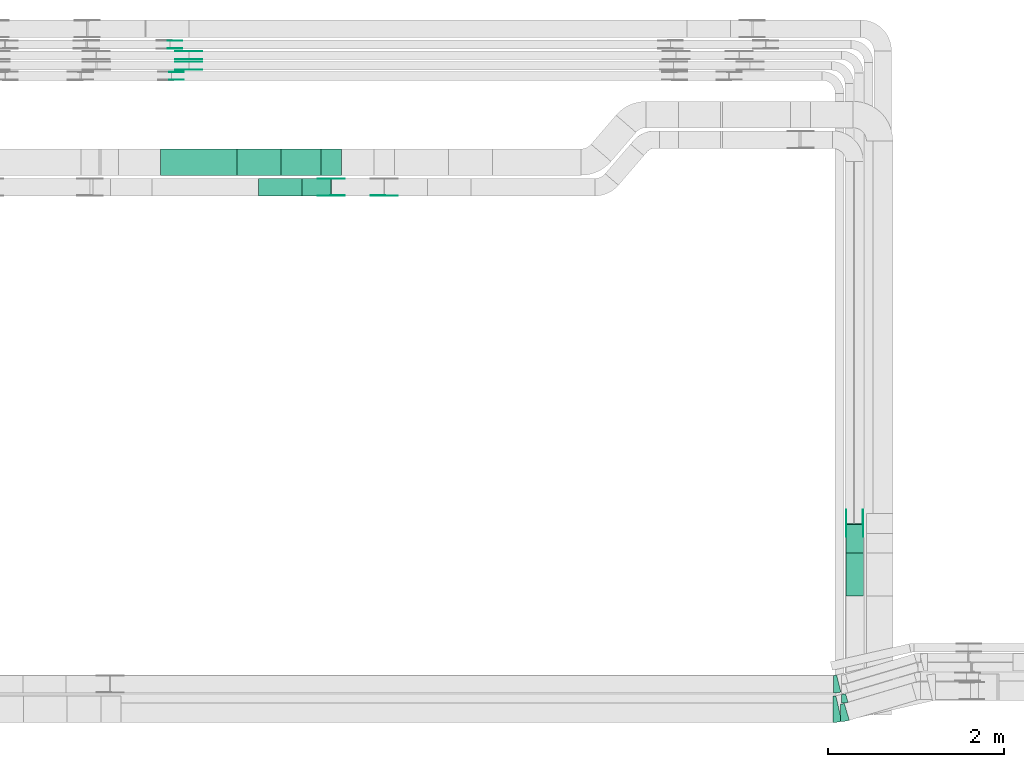
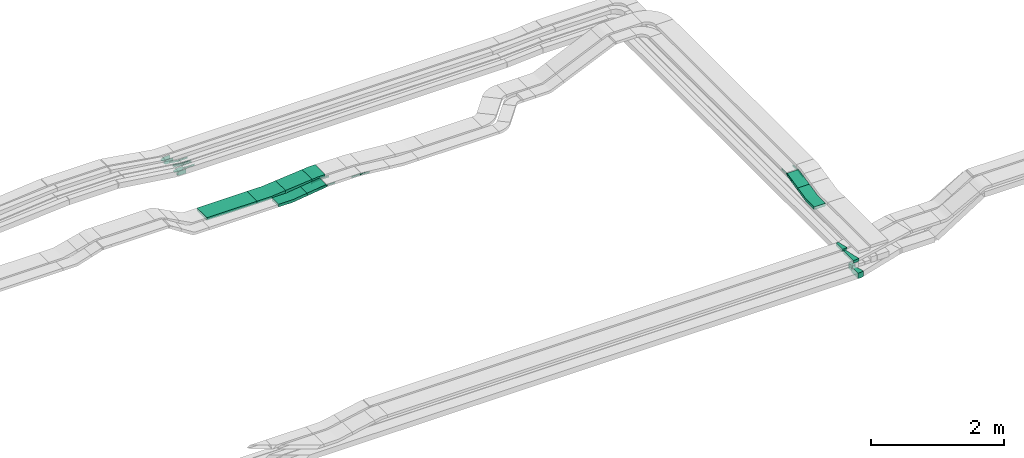
# One storey, part 19 of 28: 30 flow fittings, 4 flow segments.
"""IFC2X3 building model written with IfcOpenShell, lengths in millimetres."""

from ifc_helpers import new_model, entity, si_unit, converted_unit, derived_unit, direction, frame, frame_2d, origin, origin_2d_with_axis, place, context, subcontext, project, spatial, polyline, circle_curve, parameter, trimmed, segment, composite_curve, rectangle, outline, extrude, source, transform, mapped, material, type_object, type_shapes, element, save


model = new_model("IFC2X3")

# Units and contexts
model_context = context("Model", 3, precision=0.01, world=origin(), true_north=direction((6.12303176911189e-17, 1.0)))
body_context = subcontext(model_context, "Body", "Model", "MODEL_VIEW")
ifc_project = project(units=[si_unit("LENGTHUNIT", "METRE", prefix="MILLI"), si_unit("AREAUNIT", "SQUARE_METRE"), si_unit("VOLUMEUNIT", "CUBIC_METRE"), converted_unit("PLANEANGLEUNIT", "DEGREE", entity("IfcRatioMeasure", 0.0174532925199433), si_unit("PLANEANGLEUNIT", "RADIAN"), dimensions=[0, 0, 0, 0, 0, 0, 0]), si_unit("MASSUNIT", "GRAM", prefix="KILO"), derived_unit("MASSDENSITYUNIT", [(si_unit("MASSUNIT", "GRAM", prefix="KILO"), 1), (si_unit("LENGTHUNIT", "METRE"), -3)]), derived_unit("MOMENTOFINERTIAUNIT", [(si_unit("LENGTHUNIT", "METRE"), 4)]), si_unit("TIMEUNIT", "SECOND"), si_unit("FREQUENCYUNIT", "HERTZ"), si_unit("THERMODYNAMICTEMPERATUREUNIT", "DEGREE_CELSIUS"), derived_unit("THERMALTRANSMITTANCEUNIT", [(si_unit("MASSUNIT", "GRAM", prefix="KILO"), 1), (si_unit("THERMODYNAMICTEMPERATUREUNIT", "KELVIN"), -1), (si_unit("TIMEUNIT", "SECOND"), -3)]), derived_unit("VOLUMETRICFLOWRATEUNIT", [(si_unit("LENGTHUNIT", "METRE"), 3), (si_unit("TIMEUNIT", "SECOND"), -1)]), derived_unit("MASSFLOWRATEUNIT", [(si_unit("MASSUNIT", "GRAM", prefix="KILO"), 1), (si_unit("TIMEUNIT", "SECOND"), -1)]), derived_unit("ROTATIONALFREQUENCYUNIT", [(si_unit("TIMEUNIT", "SECOND"), -1)]), si_unit("ELECTRICCURRENTUNIT", "AMPERE"), si_unit("ELECTRICVOLTAGEUNIT", "VOLT"), si_unit("POWERUNIT", "WATT"), si_unit("FORCEUNIT", "NEWTON", prefix="KILO"), si_unit("ILLUMINANCEUNIT", "LUX"), si_unit("LUMINOUSFLUXUNIT", "LUMEN"), si_unit("LUMINOUSINTENSITYUNIT", "CANDELA"), derived_unit("USERDEFINED", [(si_unit("MASSUNIT", "GRAM", prefix="KILO"), -1), (si_unit("LENGTHUNIT", "METRE"), -2), (si_unit("TIMEUNIT", "SECOND"), 3), (si_unit("LUMINOUSFLUXUNIT", "LUMEN"), 1)]), derived_unit("LINEARVELOCITYUNIT", [(si_unit("LENGTHUNIT", "METRE"), 1), (si_unit("TIMEUNIT", "SECOND"), -1)]), si_unit("PRESSUREUNIT", "PASCAL"), derived_unit("USERDEFINED", [(si_unit("LENGTHUNIT", "METRE"), -2), (si_unit("MASSUNIT", "GRAM", prefix="KILO"), 1), (si_unit("TIMEUNIT", "SECOND"), -2)]), derived_unit("LINEARFORCEUNIT", [(si_unit("MASSUNIT", "GRAM", prefix="KILO"), 1), (si_unit("LENGTHUNIT", "METRE"), 1), (si_unit("TIMEUNIT", "SECOND"), -2), (si_unit("LENGTHUNIT", "METRE"), -1)]), derived_unit("PLANARFORCEUNIT", [(si_unit("MASSUNIT", "GRAM", prefix="KILO"), 1), (si_unit("LENGTHUNIT", "METRE"), 1), (si_unit("TIMEUNIT", "SECOND"), -2), (si_unit("LENGTHUNIT", "METRE"), -2)])], contexts=[model_context])

# Site, building, storey
site_placement = place(None, origin())
site = spatial("IfcSite", under=ifc_project, at=site_placement, CompositionType="ELEMENT")
building_placement = place(site_placement, origin())
building = spatial("IfcBuilding", under=site, at=building_placement, CompositionType="ELEMENT")
storey_placement = place(building_placement, frame((0.0, 0.0, 15900.0)))
storey = spatial("IfcBuildingStorey", under=building, at=storey_placement, CompositionType="ELEMENT", Elevation=15900.0)

# Flow segments
cable_carrier_segment_type = type_object("IfcCableCarrierSegmentType", PredefinedType="CABLETRAYSEGMENT")
flow_segment_1_placement = place(storey_placement, frame((52457.57, 14435.03, 2510.0)))
element("IfcFlowSegment", 1, at=flow_segment_1_placement, inside=storey, type_object=cable_carrier_segment_type, context=body_context, shape_type="SweptSolid", body=[
    extrude(rectangle(XDim=871.430907386971, YDim=300.000000000001, at=origin_2d_with_axis()), frame((435.72, 150.0, 0.0)), (0.0, 0.0, 1.0), 50.0000000000038),
])
flow_segment_2_placement = place(storey_placement, frame((54062.44, 14200.03, 2542.67)))
element("IfcFlowSegment", 2, at=flow_segment_2_placement, inside=storey, type_object=cable_carrier_segment_type, context=body_context, shape_type="SweptSolid", body=[
    extrude(rectangle(XDim=49.9999999999994, YDim=199.999999999998, at=origin_2d_with_axis()), frame((3.25, 100.0, 24.79), z_axis=(0.99149516870263, 0.0, 0.130143499412548), x_axis=(-0.130143499412548, 0.0, 0.99149516870263)), (0.0, 0.0, 1.0), 333.926965891303),
])
flow_segment_3_placement = place(storey_placement, frame((53824.38, 14435.03, 2533.18)))
element("IfcFlowSegment", 3, at=flow_segment_3_placement, inside=storey, type_object=cable_carrier_segment_type, context=body_context, shape_type="SweptSolid", body=[
    extrude(rectangle(XDim=50.0000000000003, YDim=300.000000000001, at=frame_2d((0.0, 0.0), x_axis=(0.0, 1.0))), frame((2.31, 150.0, 24.89), z_axis=(0.995712367928819, 0.0, 0.0925034072539187), x_axis=(0.0, 1.0, 0.0)), (0.0, 0.0, 1.0), 461.339846266049),
])
flow_segment_4_placement = place(storey_placement, frame((60246.82, 10142.24, 2935.93)))
element("IfcFlowSegment", 4, at=flow_segment_4_placement, inside=storey, type_object=cable_carrier_segment_type, context=body_context, shape_type="SweptSolid", body=[
    extrude(rectangle(XDim=49.999999999999, YDim=333.777983077564, at=frame_2d((0.0, 0.0), x_axis=(0.0, 1.0))), frame((0.0, 168.29, 61.26), z_axis=(1.0, 0.0, 0.0), x_axis=(0.0, -0.975283876332617, -0.220955562422909)), (0.0, 0.0, 1.0), 200.000000000007),
])

# Flow fittings
ifc_material_1 = material(Name="G")
cable_carrier_fitting_type_1 = type_object("IfcCableCarrierFittingType", PredefinedType="NOTDEFINED", material=ifc_material_1)
shared_shape_1 = source(origin(), body_context, "Body", "SweptSolid", [
    extrude(outline(composite_curve([segment(trimmed(circle_curve(frame_2d((-44.59, 0.0), x_axis=(1.0, 0.0)), 12.5), [parameter(90.0000000000007)], [parameter(270.0)], True, "PARAMETER"), True, "CONTINUOUS"), segment(polyline([(-44.59, -12.5), (-33.09, -12.5)]), True, "CONTINUOUS"), segment(polyline([(-33.09, -12.5), (-31.23, -14.5)]), True, "CONTINUOUS"), segment(polyline([(-31.23, -14.5), (108.91, -14.5)]), True, "CONTINUOUS"), segment(polyline([(108.91, -14.5), (108.91, 14.5)]), True, "CONTINUOUS"), segment(polyline([(108.91, 14.5), (-31.23, 14.5)]), True, "CONTINUOUS"), segment(polyline([(-31.23, 14.5), (-33.09, 12.5)]), True, "CONTINUOUS"), segment(polyline([(-33.09, 12.5), (-44.59, 12.5)]), True, "CONTINUOUS")], self_intersect=False)), frame((44.59, 0.0, 0.0), z_axis=(0.0, 0.0, -1.0), x_axis=(1.0, 0.0, 0.0)), (0.0, 0.0, -1.0), 2.0),
])
type_shapes(cable_carrier_fitting_type_1, [shared_shape_1])
flow_fitting_1_placement = place(storey_placement, frame((52777.82, 15634.0, 2642.36), z_axis=(0.0, -1.0, 0.0), x_axis=(1.0, 0.0, 0.0)))
element("IfcFlowFitting", 5, at=flow_fitting_1_placement, inside=storey, type_object=cable_carrier_fitting_type_1, material=ifc_material_1, context=body_context, shape_type="MappedRepresentation", body=[
    mapped(shared_shape_1, transform((0.0, 0.0, 0.0), scale=1.0)),
])
cable_carrier_fitting_type_2 = type_object("IfcCableCarrierFittingType", PredefinedType="NOTDEFINED", material=ifc_material_1)
type_shapes(cable_carrier_fitting_type_2, [shared_shape_1])
flow_fitting_2_placement = place(storey_placement, frame((52777.82, 15722.92, 2642.36), z_axis=(0.0, 1.0, 0.0), x_axis=(-0.990595007167102, 0.0, 0.136826648631067)))
element("IfcFlowFitting", 6, at=flow_fitting_2_placement, inside=storey, type_object=cable_carrier_fitting_type_2, material=ifc_material_1, context=body_context, shape_type="MappedRepresentation", body=[
    mapped(shared_shape_1, transform((0.0, 0.0, 0.0), scale=1.0)),
])
flow_fitting_3_placement = place(storey_placement, frame((52777.82, 15754.0, 2642.36), z_axis=(0.0, -1.0, 0.0), x_axis=(1.0, 0.0, 0.0)))
element("IfcFlowFitting", 7, at=flow_fitting_3_placement, inside=storey, type_object=cable_carrier_fitting_type_1, material=ifc_material_1, context=body_context, shape_type="MappedRepresentation", body=[
    mapped(shared_shape_1, transform((0.0, 0.0, 0.0), scale=1.0)),
])
flow_fitting_4_placement = place(storey_placement, frame((52777.82, 15842.92, 2642.36), z_axis=(0.0, 1.0, 0.0), x_axis=(-0.990663695538518, 0.0, 0.136328435559007)))
element("IfcFlowFitting", 8, at=flow_fitting_4_placement, inside=storey, type_object=cable_carrier_fitting_type_2, material=ifc_material_1, context=body_context, shape_type="MappedRepresentation", body=[
    mapped(shared_shape_1, transform((0.0, 0.0, 0.0), scale=1.0)),
])
flow_fitting_5_placement = place(storey_placement, frame((60442.28, 10477.43, 3035.0), z_axis=(1.0, 0.0, 0.0), x_axis=(0.0, -0.975283876332616, -0.220955562422916)))
element("IfcFlowFitting", 9, at=flow_fitting_5_placement, inside=storey, type_object=cable_carrier_fitting_type_1, material=ifc_material_1, context=body_context, shape_type="MappedRepresentation", body=[
    mapped(shared_shape_1, transform((0.0, 0.0, 0.0), scale=1.0)),
])
flow_fitting_6_placement = place(storey_placement, frame((60253.36, 10477.43, 3035.0), z_axis=(-1.0, 0.0, 0.0), x_axis=(0.0, 1.0, 0.0)))
element("IfcFlowFitting", 10, at=flow_fitting_6_placement, inside=storey, type_object=cable_carrier_fitting_type_2, material=ifc_material_1, context=body_context, shape_type="MappedRepresentation", body=[
    mapped(shared_shape_1, transform((0.0, 0.0, 0.0), scale=1.0)),
])
flow_fitting_7_placement = place(storey_placement, frame((54399.65, 14204.57, 2611.3), z_axis=(0.0, -1.0, 0.0), x_axis=(-0.991495168702633, 0.0, -0.130143499412525)))
element("IfcFlowFitting", 11, at=flow_fitting_7_placement, inside=storey, type_object=cable_carrier_fitting_type_1, material=ifc_material_1, context=body_context, shape_type="MappedRepresentation", body=[
    mapped(shared_shape_1, transform((0.0, 0.0, 0.0), scale=1.0)),
])
for number, where, z_axis, x_axis in (
    (12, (54399.65, 14393.49, 2611.3), (0.0, 1.0, 0.0), (1.0, 0.0, 0.0)),
    (13, (54998.38, 14206.57, 2611.3), (0.0, -1.0, 0.0), (-1.0, 0.0, 0.0)),
):
    element("IfcFlowFitting", number, at=place(storey_placement, frame(where, z_axis=z_axis, x_axis=x_axis)), inside=storey, type_object=cable_carrier_fitting_type_2, material=ifc_material_1, context=body_context, shape_type="MappedRepresentation", body=[
        mapped(shared_shape_1, transform((0.0, 0.0, 0.0), scale=1.0)),
    ])
cable_carrier_fitting_type_3 = type_object("IfcCableCarrierFittingType", PredefinedType="NOTDEFINED", material=ifc_material_1)
shared_shape_2 = source(origin(), body_context, "Body", "SweptSolid", [
    extrude(outline(composite_curve([segment(trimmed(circle_curve(frame_2d((-44.59, 0.0), x_axis=(1.0, 0.0)), 12.5), [parameter(90.0000000000007)], [parameter(270.0)], True, "PARAMETER"), True, "CONTINUOUS"), segment(polyline([(-44.59, -12.5), (-33.09, -12.5)]), True, "CONTINUOUS"), segment(polyline([(-33.09, -12.5), (-31.23, -14.5)]), True, "CONTINUOUS"), segment(polyline([(-31.23, -14.5), (108.91, -14.5)]), True, "CONTINUOUS"), segment(polyline([(108.91, -14.5), (108.91, 14.5)]), True, "CONTINUOUS"), segment(polyline([(108.91, 14.5), (-31.23, 14.5)]), True, "CONTINUOUS"), segment(polyline([(-31.23, 14.5), (-33.09, 12.5)]), True, "CONTINUOUS"), segment(polyline([(-33.09, 12.5), (-44.59, 12.5)]), True, "CONTINUOUS")], self_intersect=False)), frame((44.59, 0.0, 0.0)), (0.0, 0.0, 1.0), 2.0),
])
type_shapes(cable_carrier_fitting_type_3, [shared_shape_2])
flow_fitting_8_placement = place(storey_placement, frame((52777.82, 15724.92, 2642.36), z_axis=(0.0, 1.0, 0.0), x_axis=(1.0, 0.0, 0.0)))
element("IfcFlowFitting", 14, at=flow_fitting_8_placement, inside=storey, type_object=cable_carrier_fitting_type_3, material=ifc_material_1, context=body_context, shape_type="MappedRepresentation", body=[
    mapped(shared_shape_2, transform((0.0, 0.0, 0.0), scale=1.0)),
])
cable_carrier_fitting_type_4 = type_object("IfcCableCarrierFittingType", PredefinedType="NOTDEFINED", material=ifc_material_1)
type_shapes(cable_carrier_fitting_type_4, [shared_shape_2])
flow_fitting_9_placement = place(storey_placement, frame((52777.82, 15636.0, 2642.36), z_axis=(0.0, -1.0, 0.0), x_axis=(-0.990595007167102, 0.0, 0.136826648631067)))
element("IfcFlowFitting", 15, at=flow_fitting_9_placement, inside=storey, type_object=cable_carrier_fitting_type_4, material=ifc_material_1, context=body_context, shape_type="MappedRepresentation", body=[
    mapped(shared_shape_2, transform((0.0, 0.0, 0.0), scale=1.0)),
])
flow_fitting_10_placement = place(storey_placement, frame((52777.82, 15844.92, 2642.36), z_axis=(0.0, 1.0, 0.0), x_axis=(1.0, 0.0, 0.0)))
element("IfcFlowFitting", 16, at=flow_fitting_10_placement, inside=storey, type_object=cable_carrier_fitting_type_3, material=ifc_material_1, context=body_context, shape_type="MappedRepresentation", body=[
    mapped(shared_shape_2, transform((0.0, 0.0, 0.0), scale=1.0)),
])
flow_fitting_11_placement = place(storey_placement, frame((52777.82, 15756.0, 2642.36), z_axis=(0.0, -1.0, 0.0), x_axis=(-0.990663695538518, 0.0, 0.136328435559007)))
element("IfcFlowFitting", 17, at=flow_fitting_11_placement, inside=storey, type_object=cable_carrier_fitting_type_4, material=ifc_material_1, context=body_context, shape_type="MappedRepresentation", body=[
    mapped(shared_shape_2, transform((0.0, 0.0, 0.0), scale=1.0)),
])
flow_fitting_12_placement = place(storey_placement, frame((60251.36, 10477.43, 3035.0), z_axis=(-1.0, 0.0, 0.0), x_axis=(0.0, -0.975283876332616, -0.220955562422916)))
element("IfcFlowFitting", 18, at=flow_fitting_12_placement, inside=storey, type_object=cable_carrier_fitting_type_3, material=ifc_material_1, context=body_context, shape_type="MappedRepresentation", body=[
    mapped(shared_shape_2, transform((0.0, 0.0, 0.0), scale=1.0)),
])
flow_fitting_13_placement = place(storey_placement, frame((60440.28, 10477.43, 3035.0), z_axis=(1.0, 0.0, 0.0), x_axis=(0.0, 1.0, 0.0)))
element("IfcFlowFitting", 19, at=flow_fitting_13_placement, inside=storey, type_object=cable_carrier_fitting_type_4, material=ifc_material_1, context=body_context, shape_type="MappedRepresentation", body=[
    mapped(shared_shape_2, transform((0.0, 0.0, 0.0), scale=1.0)),
])
flow_fitting_14_placement = place(storey_placement, frame((54399.65, 14395.49, 2611.3), z_axis=(0.0, 1.0, 0.0), x_axis=(-0.991495168702633, 0.0, -0.130143499412525)))
element("IfcFlowFitting", 20, at=flow_fitting_14_placement, inside=storey, type_object=cable_carrier_fitting_type_3, material=ifc_material_1, context=body_context, shape_type="MappedRepresentation", body=[
    mapped(shared_shape_2, transform((0.0, 0.0, 0.0), scale=1.0)),
])
flow_fitting_15_placement = place(storey_placement, frame((54399.65, 14206.57, 2611.3), z_axis=(0.0, -1.0, 0.0), x_axis=(1.0, 0.0, 0.0)))
element("IfcFlowFitting", 21, at=flow_fitting_15_placement, inside=storey, type_object=cable_carrier_fitting_type_4, material=ifc_material_1, context=body_context, shape_type="MappedRepresentation", body=[
    mapped(shared_shape_2, transform((0.0, 0.0, 0.0), scale=1.0)),
])
flow_fitting_16_placement = place(storey_placement, frame((54998.38, 14204.57, 2611.3), z_axis=(0.0, -1.0, 0.0), x_axis=(0.994726726442407, 0.0, -0.1025609072755)))
element("IfcFlowFitting", 22, at=flow_fitting_16_placement, inside=storey, type_object=cable_carrier_fitting_type_3, material=ifc_material_1, context=body_context, shape_type="MappedRepresentation", body=[
    mapped(shared_shape_2, transform((0.0, 0.0, 0.0), scale=1.0)),
])
ifc_material_2 = material()
cable_carrier_fitting_type_5 = type_object("IfcCableCarrierFittingType", Name="470_DKC_S5_Variable Angle Elbow 0-45:-", PredefinedType="NOTDEFINED", material=ifc_material_2)
shared_shape_3 = source(origin(), body_context, "Body", "SweptSolid", [
    extrude(outline(composite_curve([segment(polyline([(-29.63, -54.26), (-28.63, -54.26)]), True, "CONTINUOUS"), segment(trimmed(circle_curve(frame_2d((-28.63, 195.74), x_axis=(0.0, -1.0)), 250.0), [parameter(0.0)], [parameter(16.6435818354755)], True, "PARAMETER"), True, "CONTINUOUS"), segment(polyline([(42.97, -43.79), (43.93, -43.5)]), True, "CONTINUOUS"), segment(polyline([(43.93, -43.5), (15.29, 52.31)]), True, "CONTINUOUS"), segment(polyline([(15.29, 52.31), (14.33, 52.02)]), True, "CONTINUOUS"), segment(trimmed(circle_curve(frame_2d((-28.63, 195.74), x_axis=(0.0, -1.0)), 150.0), [parameter(0.0)], [parameter(16.6435818354755)], True, "PARAMETER"), False, "CONTINUOUS"), segment(polyline([(-28.63, 45.74), (-29.63, 45.74)]), True, "CONTINUOUS"), segment(polyline([(-29.63, 45.74), (-29.63, -54.26)]), True, "CONTINUOUS")], self_intersect=False)), frame((-0.62, 4.26, -50.0)), (0.0, 0.0, 1.0), 100.0),
])
type_shapes(cable_carrier_fitting_type_5, [shared_shape_3])
flow_fitting_17_placement = place(storey_placement, frame((60228.47, 8484.97, 2550.0)))
element("IfcFlowFitting", 23, at=flow_fitting_17_placement, inside=storey, type_object=cable_carrier_fitting_type_5, material=ifc_material_2, Name="470_DKC_S5_Variable Angle Elbow 0-45:-", ObjectType="470_DKC_S5_Variable Angle Elbow 0-45:-", context=body_context, shape_type="MappedRepresentation", body=[
    mapped(shared_shape_3, transform((0.0, 0.0, 0.0), scale=1.0)),
])
cable_carrier_fitting_type_6 = type_object("IfcCableCarrierFittingType", Name="470_DKC_S5_Variable Angle Elbow 0-45:-", PredefinedType="NOTDEFINED", material=ifc_material_2)
shared_shape_4 = source(origin(), body_context, "Body", "SweptSolid", [
    extrude(outline(composite_curve([segment(polyline([(-36.79, -105.31), (-35.79, -105.31)]), True, "CONTINUOUS"), segment(trimmed(circle_curve(frame_2d((-35.79, 244.69), x_axis=(0.0, -1.0)), 350.0), [parameter(0.0)], [parameter(16.6435818354755)], True, "PARAMETER"), True, "CONTINUOUS"), segment(polyline([(64.45, -90.65), (65.41, -90.36)]), True, "CONTINUOUS"), segment(polyline([(65.41, -90.36), (8.13, 101.26)]), True, "CONTINUOUS"), segment(polyline([(8.13, 101.26), (7.17, 100.98)]), True, "CONTINUOUS"), segment(trimmed(circle_curve(frame_2d((-35.79, 244.69), x_axis=(0.0, -1.0)), 150.0), [parameter(0.0)], [parameter(16.6435818354755)], True, "PARAMETER"), False, "CONTINUOUS"), segment(polyline([(-35.79, 94.69), (-36.79, 94.69)]), True, "CONTINUOUS"), segment(polyline([(-36.79, 94.69), (-36.79, -105.31)]), True, "CONTINUOUS")], self_intersect=False)), frame((-0.78, 5.31, -50.0)), (0.0, 0.0, 1.0), 100.0),
])
type_shapes(cable_carrier_fitting_type_6, [shared_shape_4])
flow_fitting_18_placement = place(storey_placement, frame((60222.2, 8324.97, 2550.0)))
element("IfcFlowFitting", 24, at=flow_fitting_18_placement, inside=storey, type_object=cable_carrier_fitting_type_6, material=ifc_material_2, Name="470_DKC_S5_Variable Angle Elbow 0-45:-", ObjectType="470_DKC_S5_Variable Angle Elbow 0-45:-", context=body_context, shape_type="MappedRepresentation", body=[
    mapped(shared_shape_4, transform((0.0, 0.0, 0.0), scale=1.0)),
])
cable_carrier_fitting_type_7 = type_object("IfcCableCarrierFittingType", Name="470_DKC_S5_Variable Angle Elbow 0-45:-", PredefinedType="NOTDEFINED", material=ifc_material_2)
shared_shape_5 = source(origin(), body_context, "Body", "SweptSolid", [
    extrude(outline(composite_curve([segment(polyline([(-31.12, -103.74), (-30.12, -103.74)]), True, "CONTINUOUS"), segment(trimmed(circle_curve(frame_2d((-30.12, 246.26), x_axis=(0.0, -1.0)), 350.0), [parameter(0.0)], [parameter(13.9444078794154)], True, "PARAMETER"), True, "CONTINUOUS"), segment(polyline([(54.23, -93.43), (55.2, -93.19)]), True, "CONTINUOUS"), segment(polyline([(55.2, -93.19), (7.0, 100.92)]), True, "CONTINUOUS"), segment(polyline([(7.0, 100.92), (6.03, 100.68)]), True, "CONTINUOUS"), segment(trimmed(circle_curve(frame_2d((-30.12, 246.26), x_axis=(0.0, -1.0)), 150.0), [parameter(0.0)], [parameter(13.9444078794154)], True, "PARAMETER"), False, "CONTINUOUS"), segment(polyline([(-30.12, 96.26), (-31.12, 96.26)]), True, "CONTINUOUS"), segment(polyline([(-31.12, 96.26), (-31.12, -103.74)]), True, "CONTINUOUS")], self_intersect=False)), frame((-0.46, 3.74, -25.0)), (0.0, 0.0, 1.0), 50.0000000000004),
])
type_shapes(cable_carrier_fitting_type_7, [shared_shape_5])
flow_fitting_19_placement = place(storey_placement, frame((60135.78, 8650.15, 2845.0)))
element("IfcFlowFitting", 25, at=flow_fitting_19_placement, inside=storey, type_object=cable_carrier_fitting_type_7, material=ifc_material_2, Name="470_DKC_S5_Variable Angle Elbow 0-45:-", ObjectType="470_DKC_S5_Variable Angle Elbow 0-45:-", context=body_context, shape_type="MappedRepresentation", body=[
    mapped(shared_shape_5, transform((0.0, 0.0, 0.0), scale=1.0)),
])
cable_carrier_fitting_type_8 = type_object("IfcCableCarrierFittingType", Name="470_DKC_S5_Variable Angle Elbow 0-45:-", PredefinedType="NOTDEFINED", material=ifc_material_2)
shared_shape_6 = source(origin(), body_context, "Body", "SweptSolid", [
    extrude(outline(composite_curve([segment(polyline([(-34.24, -153.79), (-33.24, -153.79)]), True, "CONTINUOUS"), segment(trimmed(circle_curve(frame_2d((-33.24, 296.21), x_axis=(0.0, -1.0)), 450.0), [parameter(0.0)], [parameter(12.8070045345911)], True, "PARAMETER"), True, "CONTINUOUS"), segment(polyline([(66.51, -142.59), (67.48, -142.37)]), True, "CONTINUOUS"), segment(polyline([(67.48, -142.37), (0.98, 150.17)]), True, "CONTINUOUS"), segment(polyline([(0.98, 150.17), (0.01, 149.94)]), True, "CONTINUOUS"), segment(trimmed(circle_curve(frame_2d((-33.24, 296.21), x_axis=(0.0, -1.0)), 150.0), [parameter(0.0)], [parameter(12.8070045345911)], True, "PARAMETER"), False, "CONTINUOUS"), segment(polyline([(-33.24, 146.21), (-34.24, 146.21)]), True, "CONTINUOUS"), segment(polyline([(-34.24, 146.21), (-34.24, -153.79)]), True, "CONTINUOUS")], self_intersect=False)), frame((-0.43, 3.79, -25.0)), (0.0, 0.0, 1.0), 49.9999999999996),
])
type_shapes(cable_carrier_fitting_type_8, [shared_shape_6])
flow_fitting_20_placement = place(storey_placement, frame((60133.17, 8365.15, 2845.0)))
element("IfcFlowFitting", 26, at=flow_fitting_20_placement, inside=storey, type_object=cable_carrier_fitting_type_8, material=ifc_material_2, Name="470_DKC_S5_Variable Angle Elbow 0-45:-", ObjectType="470_DKC_S5_Variable Angle Elbow 0-45:-", context=body_context, shape_type="MappedRepresentation", body=[
    mapped(shared_shape_6, transform((0.0, 0.0, 0.0), scale=1.0)),
])
cable_carrier_fitting_type_9 = type_object("IfcCableCarrierFittingType", PredefinedType="NOTDEFINED", material=ifc_material_1)
shared_shape_7 = source(origin(), body_context, "Body", "SweptSolid", [
    extrude(outline(composite_curve([segment(trimmed(circle_curve(frame_2d((-41.47, 0.0), x_axis=(1.0, 0.0)), 25.0), [parameter(90.0000000000007)], [parameter(270.0)], True, "PARAMETER"), True, "CONTINUOUS"), segment(polyline([(-41.47, -25.0), (-29.97, -25.0)]), True, "CONTINUOUS"), segment(polyline([(-29.97, -25.0), (-28.1, -38.5)]), True, "CONTINUOUS"), segment(polyline([(-28.1, -38.5), (99.53, -38.5)]), True, "CONTINUOUS"), segment(polyline([(99.53, -38.5), (99.53, 38.5)]), True, "CONTINUOUS"), segment(polyline([(99.53, 38.5), (-28.1, 38.5)]), True, "CONTINUOUS"), segment(polyline([(-28.1, 38.5), (-29.97, 25.0)]), True, "CONTINUOUS"), segment(polyline([(-29.97, 25.0), (-41.47, 25.0)]), True, "CONTINUOUS")], self_intersect=False)), frame((41.47, 0.0, 0.0), z_axis=(0.0, 0.0, -1.0), x_axis=(1.0, 0.0, 0.0)), (0.0, 0.0, -1.0), 2.0),
])
type_shapes(cable_carrier_fitting_type_9, [shared_shape_7])
for number, where, z_axis, x_axis in (
    (27, (52562.05, 15876.53, 2665.0), (0.0, -1.0, 0.0), (1.0, 0.0, 0.0)),
    (28, (52578.49, 15521.53, 2667.03), (0.0, -1.0, 0.0), (1.0, 0.0, 0.0)),
):
    element("IfcFlowFitting", number, at=place(storey_placement, frame(where, z_axis=z_axis, x_axis=x_axis)), inside=storey, type_object=cable_carrier_fitting_type_9, material=ifc_material_1, context=body_context, shape_type="MappedRepresentation", body=[
        mapped(shared_shape_7, transform((0.0, 0.0, 0.0), scale=1.0)),
    ])
cable_carrier_fitting_type_10 = type_object("IfcCableCarrierFittingType", PredefinedType="NOTDEFINED", material=ifc_material_1)
shared_shape_8 = source(origin(), body_context, "Body", "SweptSolid", [
    extrude(outline(composite_curve([segment(trimmed(circle_curve(frame_2d((-41.47, 0.0), x_axis=(1.0, 0.0)), 25.0), [parameter(90.0000000000007)], [parameter(270.0)], True, "PARAMETER"), True, "CONTINUOUS"), segment(polyline([(-41.47, -25.0), (-29.97, -25.0)]), True, "CONTINUOUS"), segment(polyline([(-29.97, -25.0), (-28.1, -38.5)]), True, "CONTINUOUS"), segment(polyline([(-28.1, -38.5), (99.53, -38.5)]), True, "CONTINUOUS"), segment(polyline([(99.53, -38.5), (99.53, 38.5)]), True, "CONTINUOUS"), segment(polyline([(99.53, 38.5), (-28.1, 38.5)]), True, "CONTINUOUS"), segment(polyline([(-28.1, 38.5), (-29.97, 25.0)]), True, "CONTINUOUS"), segment(polyline([(-29.97, 25.0), (-41.47, 25.0)]), True, "CONTINUOUS")], self_intersect=False)), frame((41.47, 0.0, 0.0)), (0.0, 0.0, 1.0), 2.0),
])
type_shapes(cable_carrier_fitting_type_10, [shared_shape_8])
for number, where, z_axis, x_axis in (
    (29, (52562.05, 15963.45, 2665.0), (0.0, 1.0, 0.0), (1.0, 0.0, 0.0)),
    (30, (52578.49, 15608.45, 2667.03), (0.0, 1.0, 0.0), (1.0, 0.0, 0.0)),
):
    element("IfcFlowFitting", number, at=place(storey_placement, frame(where, z_axis=z_axis, x_axis=x_axis)), inside=storey, type_object=cable_carrier_fitting_type_10, material=ifc_material_1, context=body_context, shape_type="MappedRepresentation", body=[
        mapped(shared_shape_8, transform((0.0, 0.0, 0.0), scale=1.0)),
    ])
cable_carrier_fitting_type_11 = type_object("IfcCableCarrierFittingType", Name="470_DKC_S5_CS 90 internal vertical angle:-", PredefinedType="NOTDEFINED", material=ifc_material_2)
shared_shape_9 = source(origin(), body_context, "Body", "SweptSolid", [
    extrude(outline(composite_curve([segment(polyline([(-248.88, -33.41), (-8.6, -33.41)]), True, "CONTINUOUS"), segment(trimmed(circle_curve(frame_2d((-8.6, 131.59), x_axis=(0.0, -1.0)), 164.999999999999), [parameter(0.0)], [parameter(7.47788467414994)], True, "PARAMETER"), True, "CONTINUOUS"), segment(polyline([(12.87, -32.01), (251.12, -0.74)]), True, "CONTINUOUS"), segment(polyline([(251.12, -0.74), (244.61, 48.84)]), True, "CONTINUOUS"), segment(polyline([(244.61, 48.84), (6.37, 17.56)]), True, "CONTINUOUS"), segment(trimmed(circle_curve(frame_2d((-8.6, 131.59), x_axis=(0.0, -1.0)), 114.999999999999), [parameter(0.0)], [parameter(7.47788467414994)], True, "PARAMETER"), False, "CONTINUOUS"), segment(polyline([(-8.6, 16.59), (-248.88, 16.59)]), True, "CONTINUOUS"), segment(polyline([(-248.88, 16.59), (-248.88, -33.41)]), True, "CONTINUOUS")], self_intersect=False)), frame((-0.55, 8.41, -100.0)), (0.0, 0.0, 1.0), 200.0),
])
type_shapes(cable_carrier_fitting_type_11, [shared_shape_9])
flow_fitting_21_placement = place(storey_placement, frame((53818.38, 14300.03, 2535.0), z_axis=(0.0, -1.0, 0.0), x_axis=(1.0, 0.0, 0.0)))
element("IfcFlowFitting", 31, at=flow_fitting_21_placement, inside=storey, type_object=cable_carrier_fitting_type_11, material=ifc_material_2, Name="470_DKC_S5_CS 90 internal vertical angle:-", ObjectType="470_DKC_S5_CS 90 internal vertical angle:-", context=body_context, shape_type="MappedRepresentation", body=[
    mapped(shared_shape_9, transform((0.0, 0.0, 0.0), scale=1.0)),
])
cable_carrier_fitting_type_12 = type_object("IfcCableCarrierFittingType", Name="470_DKC_S5_CS 90 internal vertical angle:-", PredefinedType="NOTDEFINED", material=ifc_material_2)
shared_shape_10 = source(origin(), body_context, "Body", "SweptSolid", [
    extrude(outline(composite_curve([segment(polyline([(-249.1, -30.92), (-6.21, -30.92)]), True, "CONTINUOUS"), segment(trimmed(circle_curve(frame_2d((-6.21, 134.08), x_axis=(0.0, -1.0)), 164.999999999999), [parameter(0.0)], [parameter(5.30764273649969)], True, "PARAMETER"), True, "CONTINUOUS"), segment(polyline([(9.05, -30.21), (250.9, -7.74)]), True, "CONTINUOUS"), segment(polyline([(250.9, -7.74), (246.27, 42.04)]), True, "CONTINUOUS"), segment(polyline([(246.27, 42.04), (4.42, 19.58)]), True, "CONTINUOUS"), segment(trimmed(circle_curve(frame_2d((-6.21, 134.08), x_axis=(0.0, -1.0)), 114.999999999999), [parameter(0.0)], [parameter(5.30764273649969)], True, "PARAMETER"), False, "CONTINUOUS"), segment(polyline([(-6.21, 19.08), (-249.1, 19.08)]), True, "CONTINUOUS"), segment(polyline([(-249.1, 19.08), (-249.1, -30.92)]), True, "CONTINUOUS")], self_intersect=False)), frame((-0.27, 5.92, -150.0)), (0.0, 0.0, 1.0), 300.0),
])
type_shapes(cable_carrier_fitting_type_12, [shared_shape_10])
flow_fitting_22_placement = place(storey_placement, frame((53578.38, 14585.03, 2535.0), z_axis=(0.0, -1.0, 0.0), x_axis=(1.0, 0.0, 0.0)))
element("IfcFlowFitting", 32, at=flow_fitting_22_placement, inside=storey, type_object=cable_carrier_fitting_type_12, material=ifc_material_2, Name="470_DKC_S5_CS 90 internal vertical angle:-", ObjectType="470_DKC_S5_CS 90 internal vertical angle:-", context=body_context, shape_type="MappedRepresentation", body=[
    mapped(shared_shape_10, transform((0.0, 0.0, 0.0), scale=1.0)),
])
cable_carrier_fitting_type_13 = type_object("IfcCableCarrierFittingType", Name="470_DKC_S5_CD 90 external vertical angle:-", PredefinedType="NOTDEFINED", material=ifc_material_2)
shared_shape_11 = source(origin(), body_context, "Body", "SweptSolid", [
    extrude(outline(composite_curve([segment(polyline([(-113.96, -27.82), (-7.52, -27.82)]), True, "CONTINUOUS"), segment(trimmed(circle_curve(frame_2d((-7.52, 162.18), x_axis=(0.0, -1.0)), 189.999999999999), [parameter(0.0)], [parameter(5.30764273649969)], True, "PARAMETER"), True, "CONTINUOUS"), segment(polyline([(10.06, -27.0), (116.04, -17.15)]), True, "CONTINUOUS"), segment(polyline([(116.04, -17.15), (111.42, 32.63)]), True, "CONTINUOUS"), segment(polyline([(111.42, 32.63), (5.43, 22.79)]), True, "CONTINUOUS"), segment(trimmed(circle_curve(frame_2d((-7.52, 162.18), x_axis=(0.0, -1.0)), 139.999999999999), [parameter(0.0)], [parameter(5.30764273649969)], True, "PARAMETER"), False, "CONTINUOUS"), segment(polyline([(-7.52, 22.18), (-113.96, 22.18)]), True, "CONTINUOUS"), segment(polyline([(-113.96, 22.18), (-113.96, -27.82)]), True, "CONTINUOUS")], self_intersect=False)), frame((-0.13, 2.82, -150.0)), (0.0, 0.0, 1.0), 300.0),
])
type_shapes(cable_carrier_fitting_type_13, [shared_shape_11])
flow_fitting_23_placement = place(storey_placement, frame((54399.65, 14585.03, 2611.3), z_axis=(0.0, -1.0, 0.0), x_axis=(-1.0, 0.0, 0.0)))
element("IfcFlowFitting", 33, at=flow_fitting_23_placement, inside=storey, type_object=cable_carrier_fitting_type_13, material=ifc_material_2, Name="470_DKC_S5_CD 90 external vertical angle:-", ObjectType="470_DKC_S5_CD 90 external vertical angle:-", context=body_context, shape_type="MappedRepresentation", body=[
    mapped(shared_shape_11, transform((0.0, 0.0, 0.0), scale=1.0)),
])
cable_carrier_fitting_type_14 = type_object("IfcCableCarrierFittingType", Name="470_DKC_S5_CS 90 internal vertical angle:-", PredefinedType="NOTDEFINED", material=ifc_material_2)
shared_shape_12 = source(origin(), body_context, "Body", "SweptSolid", [
    extrude(outline(composite_curve([segment(polyline([(-248.69, -39.69), (-14.02, -39.69)]), True, "CONTINUOUS"), segment(trimmed(circle_curve(frame_2d((-14.02, 125.31), x_axis=(0.0, -1.0)), 164.999999999999), [parameter(0.0)], [parameter(12.7651639618243)], True, "PARAMETER"), True, "CONTINUOUS"), segment(polyline([(22.44, -35.61), (251.31, 16.24)]), True, "CONTINUOUS"), segment(polyline([(251.31, 16.24), (240.26, 65.0)]), True, "CONTINUOUS"), segment(polyline([(240.26, 65.0), (11.39, 13.15)]), True, "CONTINUOUS"), segment(trimmed(circle_curve(frame_2d((-14.02, 125.31), x_axis=(0.0, -1.0)), 114.999999999999), [parameter(0.0)], [parameter(12.7651639618243)], True, "PARAMETER"), False, "CONTINUOUS"), segment(polyline([(-14.02, 10.31), (-248.69, 10.31)]), True, "CONTINUOUS"), segment(polyline([(-248.69, 10.31), (-248.69, -39.69)]), True, "CONTINUOUS")], self_intersect=False)), frame((-1.64, 14.69, -100.0)), (0.0, 0.0, 1.0), 200.0),
])
type_shapes(cable_carrier_fitting_type_14, [shared_shape_12])
flow_fitting_24_placement = place(storey_placement, frame((60346.82, 9903.62, 2905.0), z_axis=(1.0, 0.0, 0.0), x_axis=(0.0, 1.0, 0.0)))
element("IfcFlowFitting", 34, at=flow_fitting_24_placement, inside=storey, type_object=cable_carrier_fitting_type_14, material=ifc_material_2, Name="470_DKC_S5_CS 90 internal vertical angle:-", ObjectType="470_DKC_S5_CS 90 internal vertical angle:-", context=body_context, shape_type="MappedRepresentation", body=[
    mapped(shared_shape_12, transform((0.0, 0.0, 0.0), scale=1.0)),
])

save(model, "model.ifc")
